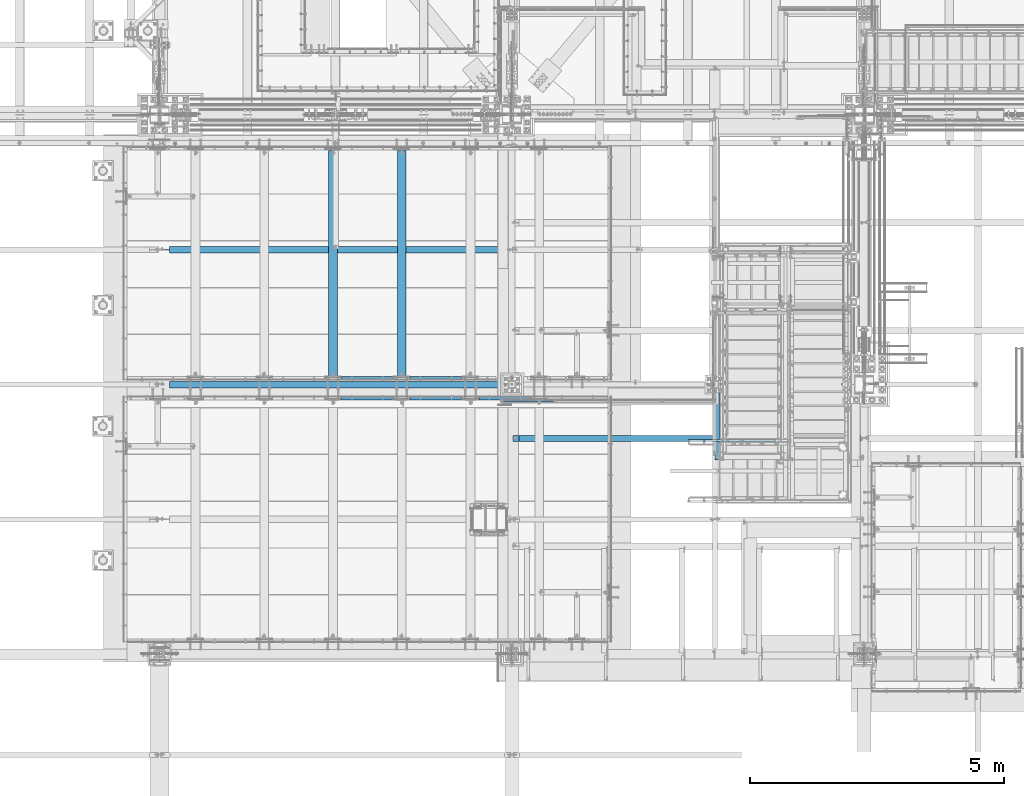
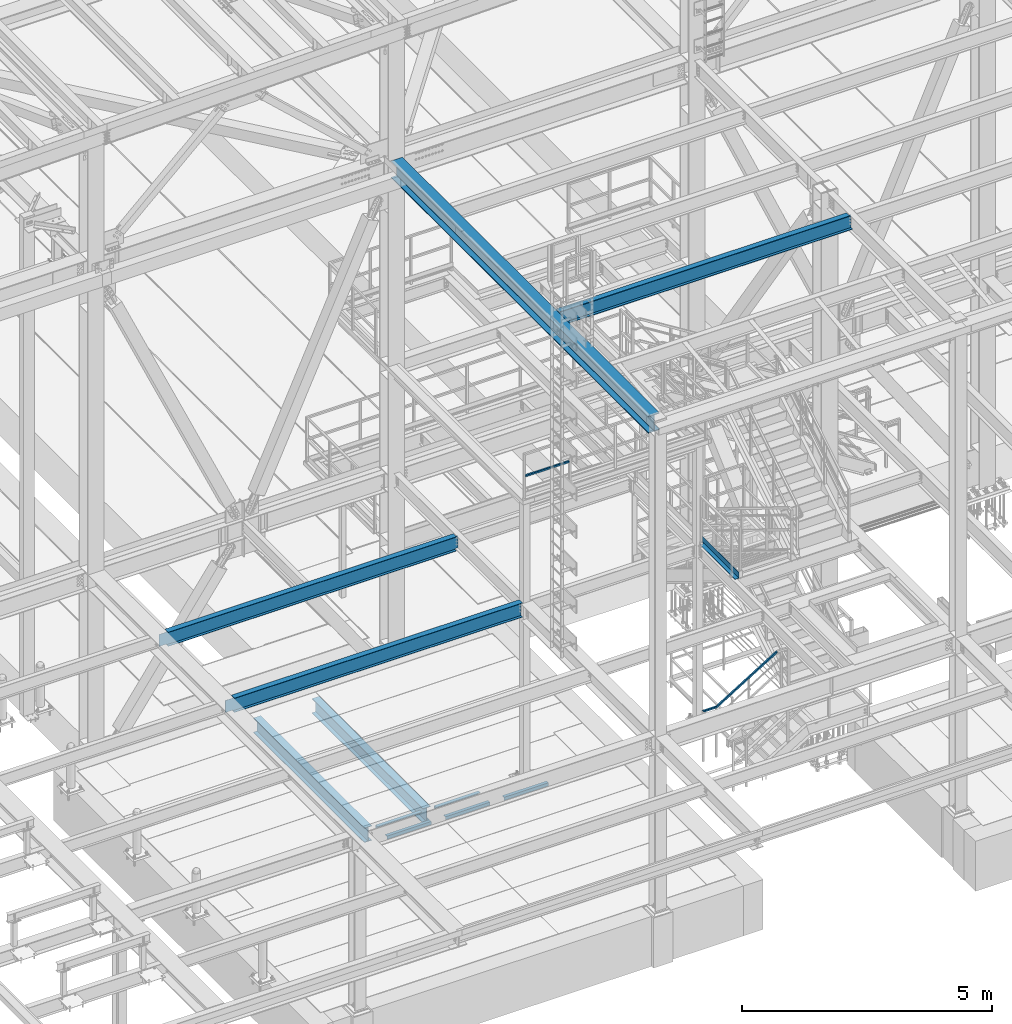
# One storey, part 1756 of 3843: 14 beams, 14 elements without a shape of their own.
"""IFC2X3 building model written with IfcOpenShell, lengths in millimetres."""

from ifc_helpers import new_model, si_unit, frame, origin_with_axes, place, context, subcontext, project, spatial, faceted_brep, material, type_object, element, aggregate, save


model = new_model("IFC2X3")

# Units and contexts
model_context = context("Model", 3, precision=1e-05, world=origin_with_axes())
body_context = subcontext(model_context, "Body", "Model", "MODEL_VIEW")
ifc_project = project(units=[si_unit("LENGTHUNIT", "METRE", prefix="MILLI"), si_unit("AREAUNIT", "SQUARE_METRE"), si_unit("VOLUMEUNIT", "CUBIC_METRE"), si_unit("MASSUNIT", "GRAM", prefix="KILO"), si_unit("TIMEUNIT", "SECOND"), si_unit("PLANEANGLEUNIT", "RADIAN"), si_unit("SOLIDANGLEUNIT", "STERADIAN"), si_unit("THERMODYNAMICTEMPERATUREUNIT", "DEGREE_CELSIUS"), si_unit("LUMINOUSINTENSITYUNIT", "LUMEN")], contexts=[model_context])

# Site, building, storey
site_placement = place(None, origin_with_axes())
site = spatial("IfcSite", under=ifc_project, at=site_placement, CompositionType="ELEMENT")
building_placement = place(site_placement, origin_with_axes())
building = spatial("IfcBuilding", under=site, at=building_placement, Name="Undefined", CompositionType="ELEMENT")
storey_placement = place(building_placement, origin_with_axes())
storey = spatial("IfcBuildingStorey", under=building, at=storey_placement, Name="Undefined", CompositionType="ELEMENT", Elevation=0.0)

# Assembly, beam
assembly_1_placement = place(storey_placement, origin_with_axes())
assembly_1 = element("IfcElementAssembly", 1, at=assembly_1_placement, inside=storey, Name="RAIL", AssemblyPlace="NOTDEFINED", PredefinedType="RIGID_FRAME")
ifc_material_1 = material()
beam_type_1 = type_object("IfcBeamType", Name="HSS1-1/2X1-1/2X1/4", PredefinedType="NOTDEFINED")
beam_1_placement = place(assembly_1_placement, frame((48799.7499877927, 19983.4499877934, 38099.9999983615), z_axis=(0.0, 0.0, 1.0), x_axis=(1.0, 0.0, 0.0)))
beam_1 = element("IfcBeam", 2, at=beam_1_placement, type_object=beam_type_1, material=ifc_material_1, Name="RAIL", ObjectType="HSS1-1/2X1-1/2X1/4", context=body_context, shape_type="Brep", body=[
    faceted_brep([(1027.11250303521, -19.0500000007705, 19.0499992350015), (1027.11250303521, -19.0499992350015, -19.0499992350015), (1027.11250303521, 19.0499992350015, -19.0499992350015), (1027.11250303521, 19.0499992350015, 19.0499992350015), (1027.11250303521, -12.6999993300014, 12.6999993299978), (1027.11250303521, 12.6999993300014, 12.6999993299978), (1027.11250303521, 12.6999993300014, -12.6999993299978), (1027.11250303521, -12.6999993300014, -12.6999993299978), (19.0499992350015, 19.0499992350015, -19.0499992350015), (19.0499992350015, 19.0499992350015, 19.0499992350015), (19.0499992350015, -19.0499992350015, 19.0499992350015), (19.0499992350015, -19.0499992350015, -19.0499992350015), (19.0499992350015, 12.6999993299978, 12.6999993299978), (19.0499992350015, -12.6999993299978, 12.6999993299978), (19.0499992350015, -12.6999993299978, -12.6999993299978), (19.0499992350015, 12.6999993299978, -12.6999993299978)], [[[0, 1, 2, 3], [4, 5, 6, 7]], [[8, 9, 3, 2]], [[9, 10, 0, 3]], [[10, 11, 1, 0]], [[11, 8, 2, 1]], [[11, 10, 9, 8], [12, 13, 14, 15]], [[14, 13, 4, 7]], [[15, 14, 7, 6]], [[12, 15, 6, 5]], [[13, 12, 5, 4]]]),
])
aggregate(assembly_1, [beam_1])

assembly_2_placement = place(storey_placement, origin_with_axes())
assembly_2 = element("IfcElementAssembly", 3, at=assembly_2_placement, inside=storey, Name="RAIL", AssemblyPlace="NOTDEFINED", PredefinedType="RIGID_FRAME")
beam_2_placement = place(assembly_2_placement, frame((54271.9209098939, 19202.4000001452, 32464.1667135371), z_axis=(0.524097425775922, 0.0, -0.851658316635875), x_axis=(-0.851658316635875, 0.0, -0.524097425775922)))
beam_2 = element("IfcBeam", 4, at=beam_2_placement, type_object=beam_type_1, material=ifc_material_1, Name="RAIL", ObjectType="HSS1-1/2X1-1/2X1/4", context=body_context, shape_type="Brep", body=[
    faceted_brep([(1755.76634726612, 19.0499992350015, 19.049998791572), (1755.76634726612, -19.0499992350015, 19.049998791572), (2003.71981394624, -19.0499992350015, -133.536749979445), (2003.71981394624, 19.0499992350015, -133.536749979445), (115.437154328312, 19.0499992350015, 19.0499992058286), (115.437154328312, -19.0499992350015, 19.0499992058286), (1744.98244024127, -19.0499992350015, -19.0499996756661), (2016.19988403501, -19.0499992350015, -185.953042059253), (104.65324729737, -19.0499992350015, -19.0499992614094), (1744.98244024127, 19.0499992350015, -19.0499996756661), (104.65324729737, 19.0499992350015, -19.0499992614094), (2016.19988403501, 19.0499992350015, -185.953042059253), (1746.77975812404, 12.6999993300014, -12.6999997711281), (1746.77975812404, -12.6999993300014, -12.6999997711281), (2014.11987176099, -12.6999993300014, -177.216992826765), (2014.11987176099, 12.6999993300014, -177.216992826765), (2005.79982557208, 12.6999993300014, -142.272798813054), (2005.79982557208, -12.6999993300014, -142.272798813054), (1753.96902938335, -12.6999993300014, 12.699998887034), (1753.96902938335, 12.6999993300014, 12.699998887034), (113.639836444549, -12.6999993300014, 12.699999301287), (113.639836444549, 12.6999993300014, 12.699999301287), (106.450565181156, 12.6999993300014, -12.6999993568714), (106.450565181156, -12.6999993300014, -12.6999993568714)], [[[0, 1, 2, 3]], [[1, 0, 4, 5]], [[6, 7, 2, 1, 5, 8]], [[9, 6, 8, 10]], [[0, 3, 11, 9, 10, 4]], [[6, 9, 11, 7]], [[12, 13, 14, 15]], [[3, 2, 7, 11], [16, 15, 14, 17]], [[18, 19, 16, 17]], [[19, 18, 20, 21]], [[12, 15, 16, 19, 21, 22]], [[13, 12, 22, 23]], [[18, 17, 14, 13, 23, 20]], [[10, 8, 5, 4], [22, 21, 20, 23]]]),
])
aggregate(assembly_2, [beam_2])

assembly_3_placement = place(storey_placement, origin_with_axes())
assembly_3 = element("IfcElementAssembly", 5, at=assembly_3_placement, inside=storey, Name="ANGLE", AssemblyPlace="NOTDEFINED", PredefinedType="RIGID_FRAME")
ifc_material_2 = material(Name="STEEL/A36")
beam_type_2 = type_object("IfcBeamType", Name="L3X3X1/4", PredefinedType="NOTDEFINED")
beam_3_placement = place(assembly_3_placement, frame((48015.5432658982, 20424.7750055596, 30365.7000030518), z_axis=(0.0, 0.0, -1.0), x_axis=(-1.0, 0.0, 0.0)))
beam_3 = element("IfcBeam", 6, at=beam_3_placement, type_object=beam_type_2, material=ifc_material_2, Name="ANGLE", ObjectType="L3X3X1/4", context=body_context, shape_type="Brep", body=[
    faceted_brep([(0.0, 38.0999999999985, -38.0999999999985), (0.0, 38.0999999999985, 38.0999999999985), (1022.33317453146, 38.1000000000004, 38.0999999999985), (1022.33317453146, 38.1000000000004, -38.0999999999985), (0.0, 31.75, 38.0999999999985), (1022.33317453146, 31.75, 38.0999999999985), (0.0, 31.75, -31.75), (1022.33317453146, 31.75, -31.75), (0.0, -38.0999999999985, -31.75), (1022.33317453146, -38.1000000000004, -31.75), (0.0, -38.0999999999985, -38.0999999999985), (1022.33317453146, -38.1000000000004, -38.0999999999985)], [[[0, 1, 2, 3]], [[1, 4, 5, 2]], [[4, 6, 7, 5]], [[6, 8, 9, 7]], [[8, 10, 11, 9]], [[10, 0, 3, 11]], [[5, 7, 9, 11, 3, 2]], [[10, 8, 6, 4, 1, 0]]]),
])
aggregate(assembly_3, [beam_3])

assembly_4_placement = place(storey_placement, origin_with_axes())
assembly_4 = element("IfcElementAssembly", 7, at=assembly_4_placement, inside=storey, Name="ANGLE", AssemblyPlace="NOTDEFINED", PredefinedType="RIGID_FRAME")
beam_4_placement = place(assembly_4_placement, frame((46662.9932658982, 20424.7750055596, 30365.7000030518), z_axis=(0.0, 0.0, -1.0), x_axis=(-1.0, 0.0, 0.0)))
beam_4 = element("IfcBeam", 8, at=beam_4_placement, type_object=beam_type_2, material=ifc_material_2, Name="ANGLE", ObjectType="L3X3X1/4", context=body_context, shape_type="Brep", body=[
    faceted_brep([(0.0, 38.0999999999985, -38.0999999999985), (0.0, 38.0999999999985, 38.0999999999985), (1022.33317453146, 38.1000000000004, 38.0999999999985), (1022.33317453146, 38.1000000000004, -38.0999999999985), (0.0, 31.75, 38.0999999999985), (1022.33317453146, 31.75, 38.0999999999985), (0.0, 31.75, -31.75), (1022.33317453146, 31.75, -31.75), (0.0, -38.0999999999985, -31.75), (1022.33317453146, -38.1000000000004, -31.75), (0.0, -38.0999999999985, -38.0999999999985), (1022.33317453146, -38.1000000000004, -38.0999999999985)], [[[0, 1, 2, 3]], [[1, 4, 5, 2]], [[4, 6, 7, 5]], [[6, 8, 9, 7]], [[8, 10, 11, 9]], [[10, 0, 3, 11]], [[5, 7, 9, 11, 3, 2]], [[10, 8, 6, 4, 1, 0]]]),
])
aggregate(assembly_4, [beam_4])

assembly_5_placement = place(storey_placement, origin_with_axes())
assembly_5 = element("IfcElementAssembly", 9, at=assembly_5_placement, inside=storey, Name="ANGLE", AssemblyPlace="NOTDEFINED", PredefinedType="RIGID_FRAME")
beam_5_placement = place(assembly_5_placement, frame((48345.7242797851, 20043.7749980702, 30365.7000030518), z_axis=(0.0, 0.0, -1.0), x_axis=(1.0, 0.0, 0.0)))
beam_5 = element("IfcBeam", 10, at=beam_5_placement, type_object=beam_type_2, material=ifc_material_2, Name="ANGLE", ObjectType="L3X3X1/4", context=body_context, shape_type="Brep", body=[
    faceted_brep([(0.0, 38.0999999999985, -38.0999999999985), (0.0, 38.0999999999985, 38.0999999999985), (1022.33317453146, 38.1000000000004, 38.0999999999985), (1022.33317453146, 38.1000000000004, -38.0999999999985), (0.0, 31.75, 38.0999999999985), (1022.33317453146, 31.75, 38.0999999999985), (0.0, 31.75, -31.75), (1022.33317453146, 31.75, -31.75), (0.0, -38.0999999999985, -31.75), (1022.33317453146, -38.1000000000004, -31.75), (0.0, -38.0999999999985, -38.0999999999985), (1022.33317453146, -38.1000000000004, -38.0999999999985)], [[[0, 1, 2, 3]], [[1, 4, 5, 2]], [[4, 6, 7, 5]], [[6, 8, 9, 7]], [[8, 10, 11, 9]], [[10, 0, 3, 11]], [[5, 7, 9, 11, 3, 2]], [[10, 8, 6, 4, 1, 0]]]),
])
aggregate(assembly_5, [beam_5])

assembly_6_placement = place(storey_placement, origin_with_axes())
assembly_6 = element("IfcElementAssembly", 11, at=assembly_6_placement, inside=storey, Name="ANGLE", AssemblyPlace="NOTDEFINED", PredefinedType="RIGID_FRAME")
beam_6_placement = place(assembly_6_placement, frame((46993.1742797851, 20043.7749972574, 30365.7000030518), z_axis=(0.0, 0.0, -1.0), x_axis=(1.0, 0.0, 0.0)))
beam_6 = element("IfcBeam", 12, at=beam_6_placement, type_object=beam_type_2, material=ifc_material_2, Name="ANGLE", ObjectType="L3X3X1/4", context=body_context, shape_type="Brep", body=[
    faceted_brep([(0.0, 38.0999999999985, -38.0999999999985), (0.0, 38.0999999999985, 38.0999999999985), (1022.33317453146, 38.1000000000004, 38.0999999999985), (1022.33317453146, 38.1000000000004, -38.0999999999985), (0.0, 31.75, 38.0999999999985), (1022.33317453146, 31.75, 38.0999999999985), (0.0, 31.75, -31.75), (1022.33317453146, 31.75, -31.75), (0.0, -38.0999999999985, -31.75), (1022.33317453146, -38.1000000000004, -31.75), (0.0, -38.0999999999985, -38.0999999999985), (1022.33317453146, -38.1000000000004, -38.0999999999985)], [[[0, 1, 2, 3]], [[1, 4, 5, 2]], [[4, 6, 7, 5]], [[6, 8, 9, 7]], [[8, 10, 11, 9]], [[10, 0, 3, 11]], [[5, 7, 9, 11, 3, 2]], [[10, 8, 6, 4, 1, 0]]]),
])
aggregate(assembly_6, [beam_6])

assembly_7_placement = place(storey_placement, origin_with_axes())
assembly_7 = element("IfcElementAssembly", 13, at=assembly_7_placement, inside=storey, Name="ANGLE", AssemblyPlace="NOTDEFINED", PredefinedType="RIGID_FRAME")
beam_7_placement = place(assembly_7_placement, frame((45640.6242797851, 20043.7749970828, 30365.7000030518), z_axis=(0.0, 0.0, -1.0), x_axis=(1.0, 0.0, 0.0)))
beam_7 = element("IfcBeam", 14, at=beam_7_placement, type_object=beam_type_2, material=ifc_material_2, Name="ANGLE", ObjectType="L3X3X1/4", context=body_context, shape_type="Brep", body=[
    faceted_brep([(0.0, 38.0999999999985, -38.0999999999985), (0.0, 38.0999999999985, 38.0999999999985), (1022.33317453146, 38.1000000000004, 38.0999999999985), (1022.33317453146, 38.1000000000004, -38.0999999999985), (0.0, 31.75, 38.0999999999985), (1022.33317453146, 31.75, 38.0999999999985), (0.0, 31.75, -31.75), (1022.33317453146, 31.75, -31.75), (0.0, -38.0999999999985, -31.75), (1022.33317453146, -38.1000000000004, -31.75), (0.0, -38.0999999999985, -38.0999999999985), (1022.33317453146, -38.1000000000004, -38.0999999999985)], [[[0, 1, 2, 3]], [[1, 4, 5, 2]], [[4, 6, 7, 5]], [[6, 8, 9, 7]], [[8, 10, 11, 9]], [[10, 0, 3, 11]], [[5, 7, 9, 11, 3, 2]], [[10, 8, 6, 4, 1, 0]]]),
])
aggregate(assembly_7, [beam_7])

assembly_8_placement = place(storey_placement, origin_with_axes())
assembly_8 = element("IfcElementAssembly", 15, at=assembly_8_placement, inside=storey, Name="BEAM", AssemblyPlace="NOTDEFINED", PredefinedType="RIGID_FRAME")
beam_type_3 = type_object("IfcBeamType", PredefinedType="NOTDEFINED")
beam_8_placement = place(assembly_8_placement, frame((52990.75, 19562.7625, 34813.875), z_axis=(0.0, -1.0, 0.0), x_axis=(1.0, 0.0, 0.0)))
beam_8 = element("IfcBeam", 16, at=beam_8_placement, type_object=beam_type_3, material=ifc_material_2, Name="BENT_PLATE", context=body_context, shape_type="Brep", body=[
    faceted_brep([(82.5500030517578, -3.17500000000291, -655.637500000001), (82.5500030517578, 3.17500000000291, -655.637500000001), (82.5500030517578, 3.17500000000291, -741.362499999999), (82.5500030517578, -3.17500000000291, -741.362499999999), (0.0, -3.17500000000291, -655.637500000001), (0.0, 3.17500000000291, -655.637500000001), (88.8999984741167, 3.17500000000291, 741.362499999999), (0.0, 3.17500000000291, 741.362499999999), (0.0, -3.17500000000291, 741.362499999999), (95.2499984741225, -3.17500000000291, 741.362499999999), (95.2499984741225, 136.524996948239, 741.362499999999), (88.8999984741167, 136.524996948239, 741.362499999999), (88.8999984741167, 3.17500000000291, -741.362499999999), (88.8999984741167, 136.524996948239, -741.362499999999), (95.2499984741225, 136.524996948239, -741.362499999999), (95.2499984741225, -3.17500000000291, -741.362499999999)], [[[0, 1, 2, 3]], [[4, 5, 1, 0]], [[6, 7, 8, 9, 10, 11]], [[12, 6, 11, 13]], [[10, 14, 13, 11]], [[9, 15, 14, 10]], [[12, 13, 14, 15, 3, 2]], [[7, 6, 12, 2, 1, 5]], [[8, 7, 5, 4]], [[15, 9, 8, 4, 0, 3]]]),
])
aggregate(assembly_8, [beam_8])

assembly_9_placement = place(storey_placement, origin_with_axes())
assembly_9 = element("IfcElementAssembly", 17, at=assembly_9_placement, inside=storey, Name="BEAM", AssemblyPlace="NOTDEFINED", PredefinedType="RIGID_FRAME")
ifc_material_3 = material(Name="STEEL/A992")
beam_type_4 = type_object("IfcBeamType", Name="W16X67", PredefinedType="NOTDEFINED")
beam_9_placement = place(assembly_9_placement, frame((48996.6, 14998.7, 42260.8375), z_axis=(0.0, 0.0, 1.0), x_axis=(0.0, 1.0, 0.0)))
beam_9 = element("IfcBeam", 18, at=beam_9_placement, type_object=beam_type_4, material=ifc_material_3, Name="BEAM", ObjectType="W16X67", context=body_context, shape_type="Brep", body=[
    faceted_brep([(142.874999999998, -130.175000000003, -207.962500000001), (142.874999999998, 130.175000000003, -207.962500000001), (10426.7, 130.175000000003, -207.962500000001), (10426.7, -130.175000000003, -207.962500000001), (142.874999999998, -130.175000000003, -190.5), (142.874999999998, -4.76249999999709, -190.5), (142.874999999998, -4.76249999999709, 190.5), (142.874999999998, -130.175000000003, 190.5), (142.874999999998, -130.175000000003, 207.962500000001), (142.874999999998, 130.175000000003, 207.962500000001), (142.874999999998, 130.175000000003, 190.5), (142.874999999998, 4.76249999999709, 190.5), (142.874999999998, 4.76249999999709, -190.5), (142.874999999998, 130.175000000003, -190.5), (10426.7, -130.175000000003, -190.5), (10426.7, -4.76249999999709, -190.5), (10426.7, -4.76249999999709, 190.5), (10426.7, -130.175000000003, 190.5), (10426.7, -130.175000000003, 207.962500000001), (10426.7, 130.175000000003, 207.962500000001), (10426.7, 130.175000000003, 190.5), (10426.7, 4.76249999999709, 190.5), (10426.7, 4.76249999999709, -190.5), (10426.7, 130.175000000003, -190.5)], [[[0, 1, 2, 3]], [[0, 4, 5, 6, 7, 8, 9, 10, 11, 12, 13, 1]], [[5, 4, 14, 15]], [[6, 5, 15, 16]], [[7, 6, 16, 17]], [[8, 7, 17, 18]], [[9, 8, 18, 19]], [[10, 9, 19, 20]], [[11, 10, 20, 21]], [[12, 11, 21, 22]], [[13, 12, 22, 23]], [[1, 13, 23, 2]], [[22, 21, 20, 19, 18, 17, 16, 15, 14, 3, 2, 23]], [[4, 0, 3, 14]]]),
])
aggregate(assembly_9, [beam_9])

assembly_10_placement = place(storey_placement, origin_with_axes())
assembly_10 = element("IfcElementAssembly", 19, at=assembly_10_placement, inside=storey, Name="BEAM", AssemblyPlace="NOTDEFINED", PredefinedType="RIGID_FRAME")
beam_type_5 = type_object("IfcBeamType", Name="W14X26", PredefinedType="NOTDEFINED")
beam_10_placement = place(assembly_10_placement, frame((48996.6, 19245.58, 42292.5875), z_axis=(0.0, 0.0, 1.0), x_axis=(1.0, 0.0, 0.0)))
beam_10 = element("IfcBeam", 20, at=beam_10_placement, type_object=beam_type_5, material=ifc_material_3, Name="BEAM", ObjectType="W14X26", context=body_context, shape_type="Brep", body=[
    faceted_brep([(6851.64999694825, -63.5, 176.212500000001), (6851.64999694825, -63.5, 165.099999999999), (6851.64999694825, -3.17499999999927, 165.099999999999), (6851.64999694825, -3.17499999999927, 160.33749980927), (6851.64999694825, 3.17499999999927, 160.33749980927), (6851.64999694825, 3.17499999999927, 165.099999999999), (6851.64999694825, 63.5, 165.099999999999), (6851.64999694825, 63.5, 176.212500000001), (6852.61672687083, -3.17499999999927, 155.477420291223), (6852.61672687083, 3.17499999999927, 155.477420291223), (6855.36974077131, -3.17499999999927, 151.357243823069), (6855.36974077131, 3.17499999999927, 151.357243823069), (6859.48991723947, -3.17499999999927, 148.604229922596), (6859.48991723947, 3.17499999999927, 148.604229922596), (6864.34999675751, -3.17499999999927, 147.637500000004), (6864.34999675751, 3.17499999999927, 147.637500000004), (6918.325, -3.17499999999927, 147.637500000004), (6918.325, 3.17499999999927, 147.637500000004), (142.87500610351, -63.5, 176.212500000001), (142.87500610351, 63.5, 176.212500000001), (142.87500610351, 63.5, 165.099999999999), (142.87500610351, 3.17499999999927, 165.099999999999), (142.87500610351, 3.17499999999927, 149.224999809267), (142.87500610351, -3.17499999999927, 149.224999809267), (142.87500610351, -3.17499999999927, 165.099999999999), (142.87500610351, -63.5, 165.099999999999), (141.908276180919, 3.17499999999927, 144.36492029122), (141.908276180919, -3.17499999999927, 144.36492029122), (139.155262280445, 3.17499999999927, 140.244743823067), (139.155262280445, -3.17499999999927, 140.244743823067), (135.035085812291, 3.17499999999927, 137.491729922593), (135.035085812291, -3.17499999999927, 137.491729922593), (130.175006294245, 3.17499999999927, 136.525000000001), (130.175006294245, -3.17499999999927, 136.525000000001), (17.4624999999942, 3.17499999999927, 136.525000000001), (17.4624999999942, -3.17499999999927, 136.525000000001), (17.4624999999942, 3.17499999999927, 125.412499999999), (17.4624999999942, 3.17499999999927, -105.1875), (17.4624999999942, 3.17499999999927, -165.099999999999), (17.4624999999942, 63.5, -165.099999999999), (17.4624999999942, 63.5, -176.212500000001), (17.4624999999942, -63.5, -176.212500000001), (17.4624999999942, -63.5, -165.099999999999), (17.4624999999942, -3.17499999999927, -165.099999999999), (6918.325, 3.17499999999927, -165.099999999999), (6918.325, 63.5, -165.099999999999), (6918.325, 63.5, -176.212500000001), (6918.325, -63.5, -176.212500000001), (6918.325, -63.5, -165.099999999999), (6918.325, -3.17499999999927, -165.099999999999), (6918.325, 3.17499999999927, 125.412499999999), (6918.325, 3.17499999999927, -105.1875)], [[[0, 1, 2, 3, 4, 5, 6, 7]], [[8, 9, 4, 3]], [[10, 11, 9, 8]], [[12, 13, 11, 10]], [[14, 15, 13, 12]], [[16, 17, 15, 14]], [[18, 19, 20, 21, 22, 23, 24, 25]], [[23, 22, 26, 27]], [[27, 26, 28, 29]], [[29, 28, 30, 31]], [[31, 30, 32, 33]], [[33, 32, 34, 35]], [[36, 37, 38, 39, 40, 41, 42, 43, 35, 34]], [[39, 38, 44, 45]], [[40, 39, 45, 46]], [[41, 40, 46, 47]], [[42, 41, 47, 48]], [[43, 42, 48, 49]], [[12, 10, 8, 3, 2, 24, 23, 27, 29, 31, 33, 35, 43, 49, 16, 14]], [[25, 24, 2, 1]], [[18, 25, 1, 0]], [[19, 18, 0, 7]], [[20, 19, 7, 6]], [[21, 20, 6, 5]], [[50, 51, 44, 38, 37, 36, 34, 32, 30, 28, 26, 22, 21, 5, 4, 9, 11, 13, 15, 17]], [[49, 48, 47, 46, 45, 44, 51, 50, 17, 16]]]),
])
aggregate(assembly_10, [beam_10])

assembly_11_placement = place(storey_placement, origin_with_axes())
assembly_11 = element("IfcElementAssembly", 21, at=assembly_11_placement, inside=storey, Name="BEAM", AssemblyPlace="NOTDEFINED", PredefinedType="RIGID_FRAME")
beam_type_6 = type_object("IfcBeamType", Name="W14X22", PredefinedType="NOTDEFINED")
beam_11_placement = place(assembly_11_placement, frame((42062.4, 20307.3, 34636.075), z_axis=(0.0, 0.0, 1.0), x_axis=(1.0, 0.0, 0.0)))
beam_11 = element("IfcBeam", 22, at=beam_11_placement, type_object=beam_type_6, material=ifc_material_3, Name="BEAM", ObjectType="W14X22", context=body_context, shape_type="Brep", body=[
    faceted_brep([(6845.3, -63.5, 166.6875), (6845.3, -63.5, 174.625), (196.849999999999, -63.5, 174.625), (196.849999999999, -63.5, 166.6875), (6845.3, 63.5, 174.625), (196.849999999999, 63.5, 174.625), (6845.3, 63.5, 166.6875), (196.849999999999, 63.5, 166.6875), (6845.3, 3.17499999999927, 166.6875), (196.849999999999, 3.17499999999927, 166.6875), (184.150000190733, -3.17499999999927, 142.874999999985), (184.150000190733, 3.17499999999927, 142.874999999985), (19.0499999999956, 3.17499999999927, 142.874999999985), (19.0499999999956, -3.17499999999927, 142.874999999985), (189.01007970878, -3.17499999999927, 143.841729922577), (189.01007970878, 3.17499999999927, 143.841729922577), (193.130256176933, -3.17499999999927, 146.594743823051), (193.130256176933, 3.17499999999927, 146.594743823051), (195.883270077407, -3.17499999999927, 150.714920291204), (195.883270077407, 3.17499999999927, 150.714920291204), (196.849999999999, -3.17499999999927, 155.574999809251), (196.849999999999, 3.17499999999927, 155.574999809251), (196.849999999999, -3.17499999999927, 166.6875), (6845.3, -3.17499999999927, 166.6875), (6845.3, 3.17499999999927, -166.6875), (6845.3, -3.17499999999927, -166.6875), (6845.3, -63.5, -166.6875), (6845.3, -63.5, -174.625), (6845.3, 63.5, -174.625), (6845.3, 63.5, -166.6875), (196.850000000006, -63.5, -166.6875), (196.850000000006, -63.5, -174.625), (196.850000000006, 63.5, -174.625), (196.850000000006, 63.5, -166.6875), (196.850000000006, 3.17499999999927, -166.6875), (193.130256176941, 3.17499999999927, -152.944743823078), (189.010079708787, 3.17499999999927, -150.191729922604), (184.150000190741, 3.17499999999927, -149.225000000013), (19.0499999999956, 3.17499999999927, -149.225000000013), (19.0499999999956, 3.17499999999927, -106.775000000001), (19.0499999999956, 3.17499999999927, 123.824999999997), (196.850000000006, 3.17499999999927, -161.924999809278), (195.883270077415, 3.17499999999927, -157.064920291232), (19.0499999999956, -3.17499999999927, -149.225000000013), (184.150000190741, -3.17499999999927, -149.225000000013), (189.010079708787, -3.17499999999927, -150.191729922604), (193.130256176941, -3.17499999999927, -152.944743823078), (195.883270077415, -3.17499999999927, -157.064920291232), (196.850000000006, -3.17499999999927, -161.924999809278), (196.850000000006, -3.17499999999927, -166.6875)], [[[0, 1, 2, 3]], [[1, 4, 5, 2]], [[4, 6, 7, 5]], [[6, 8, 9, 7]], [[10, 11, 12, 13]], [[14, 15, 11, 10]], [[16, 17, 15, 14]], [[18, 19, 17, 16]], [[20, 21, 19, 18]], [[2, 5, 7, 9, 21, 20, 22, 3]], [[23, 0, 3, 22]], [[24, 8, 6, 4, 1, 0, 23, 25, 26, 27, 28, 29]], [[27, 26, 30, 31]], [[28, 27, 31, 32]], [[29, 28, 32, 33]], [[24, 29, 33, 34]], [[35, 36, 37, 38, 39, 40, 12, 11, 15, 17, 19, 21, 9, 8, 24, 34, 41, 42]], [[13, 12, 40, 39, 38, 43]], [[25, 23, 22, 20, 18, 16, 14, 10, 13, 43, 44, 45, 46, 47, 48, 49]], [[26, 25, 49, 30]], [[48, 41, 34, 33, 32, 31, 30, 49]], [[47, 42, 41, 48]], [[46, 35, 42, 47]], [[45, 36, 35, 46]], [[44, 37, 36, 45]], [[43, 38, 37, 44]]]),
])
aggregate(assembly_11, [beam_11])

assembly_12_placement = place(storey_placement, origin_with_axes())
assembly_12 = element("IfcElementAssembly", 23, at=assembly_12_placement, inside=storey, Name="BEAM", AssemblyPlace="NOTDEFINED", PredefinedType="RIGID_FRAME")
beam_12_placement = place(assembly_12_placement, frame((42062.4, 22961.6, 34636.075), z_axis=(0.0, 0.0, 1.0), x_axis=(1.0, 0.0, 0.0)))
beam_12 = element("IfcBeam", 24, at=beam_12_placement, type_object=beam_type_6, material=ifc_material_3, Name="BEAM", ObjectType="W14X22", context=body_context, shape_type="Brep", body=[
    faceted_brep([(6854.825, -3.17499999999927, -166.6875), (6854.825, -63.5, -166.6875), (6854.825, -63.5, -174.625), (6854.825, 63.5, -174.625), (6854.825, 63.5, -166.6875), (6854.825, 3.17499999999927, -166.6875), (6854.825, 3.17499999999927, -161.924999809264), (6854.825, -3.17499999999927, -161.924999809264), (6855.79172992259, 3.17499999999927, -157.064920291217), (6855.79172992259, -3.17499999999927, -157.064920291217), (6858.54474382306, 3.17499999999927, -152.944743823064), (6858.54474382306, -3.17499999999927, -152.944743823064), (6862.66492029122, 3.17499999999927, -150.19172992259), (6862.66492029122, -3.17499999999927, -150.19172992259), (6867.52499980926, 3.17499999999927, -149.224999999999), (6867.52499980926, -3.17499999999927, -149.224999999999), (6918.325, -3.17499999999927, -149.224999999999), (6918.325, 3.17499999999927, -149.224999999999), (196.849999999999, 3.17499999999927, 166.6875), (196.849999999999, 63.5, 166.6875), (6854.825, 63.5, 166.6875), (6854.825, 3.17499999999927, 166.6875), (196.850000000006, -3.17499999999927, -161.924999809278), (196.850000000006, 3.17499999999927, -161.924999809278), (196.850000000006, 3.17499999999927, -166.6875), (196.850000000006, 63.5, -166.6875), (196.850000000006, 63.5, -174.625), (196.850000000006, -63.5, -174.625), (196.850000000006, -63.5, -166.6875), (196.850000000006, -3.17499999999927, -166.6875), (195.883270077415, -3.17499999999927, -157.064920291232), (195.883270077415, 3.17499999999927, -157.064920291232), (193.130256176941, -3.17499999999927, -152.944743823078), (193.130256176941, 3.17499999999927, -152.944743823078), (189.010079708787, -3.17499999999927, -150.191729922604), (189.010079708787, 3.17499999999927, -150.191729922604), (184.150000190741, -3.17499999999927, -149.225000000013), (184.150000190741, 3.17499999999927, -149.225000000013), (19.0499999999956, -3.17499999999927, -149.225000000013), (19.0499999999956, 3.17499999999927, -149.225000000013), (19.0499999999956, -3.17499999999927, 142.874999999985), (19.0499999999956, 3.17499999999927, 142.874999999985), (19.0499999999956, 3.17499999999927, 123.824999999997), (19.0499999999956, 3.17499999999927, -106.775000000001), (184.150000190733, -3.17499999999927, 142.874999999985), (184.150000190733, 3.17499999999927, 142.874999999985), (189.01007970878, -3.17499999999927, 143.841729922577), (189.01007970878, 3.17499999999927, 143.841729922577), (193.130256176933, -3.17499999999927, 146.594743823051), (193.130256176933, 3.17499999999927, 146.594743823051), (195.883270077407, -3.17499999999927, 150.714920291204), (195.883270077407, 3.17499999999927, 150.714920291204), (196.849999999999, -3.17499999999927, 155.574999809251), (196.849999999999, 3.17499999999927, 155.574999809251), (196.849999999999, -63.5, 174.625), (196.849999999999, 63.5, 174.625), (196.849999999999, -3.17499999999927, 166.6875), (196.849999999999, -63.5, 166.6875), (6854.825, -3.17499999999927, 166.6875), (6854.825, -63.5, 166.6875), (6854.825, -63.5, 174.625), (6854.825, 63.5, 174.625), (6854.825, -3.17499999999927, 161.924999809264), (6854.825, 3.17499999999927, 161.924999809264), (6855.79172992259, -3.17499999999927, 157.064920291217), (6855.79172992259, 3.17499999999927, 157.064920291217), (6858.54474382306, -3.17499999999927, 152.944743823064), (6858.54474382306, 3.17499999999927, 152.944743823064), (6862.66492029122, -3.17499999999927, 150.19172992259), (6862.66492029122, 3.17499999999927, 150.19172992259), (6867.52499980926, -3.17499999999927, 149.224999999999), (6867.52499980926, 3.17499999999927, 149.224999999999), (6918.325, -3.17499999999927, 149.224999999999), (6918.325, 3.17499999999927, 149.224999999999), (6918.325, 3.17499999999927, -94.0749999999971), (6918.325, 3.17499999999927, 136.525000000001)], [[[0, 1, 2, 3, 4, 5, 6, 7]], [[7, 6, 8, 9]], [[9, 8, 10, 11]], [[11, 10, 12, 13]], [[13, 12, 14, 15]], [[16, 15, 14, 17]], [[18, 19, 20, 21]], [[22, 23, 24, 25, 26, 27, 28, 29]], [[30, 31, 23, 22]], [[32, 33, 31, 30]], [[34, 35, 33, 32]], [[36, 37, 35, 34]], [[38, 39, 37, 36]], [[40, 41, 42, 43, 39, 38]], [[44, 45, 41, 40]], [[46, 47, 45, 44]], [[48, 49, 47, 46]], [[50, 51, 49, 48]], [[52, 53, 51, 50]], [[54, 55, 19, 18, 53, 52, 56, 57]], [[57, 56, 58, 59]], [[54, 57, 59, 60]], [[55, 54, 60, 61]], [[19, 55, 61, 20]], [[60, 59, 58, 62, 63, 21, 20, 61]], [[64, 65, 63, 62]], [[66, 67, 65, 64]], [[68, 69, 67, 66]], [[70, 71, 69, 68]], [[72, 73, 71, 70]], [[74, 75, 73, 72, 16, 17]], [[12, 10, 8, 6, 5, 24, 23, 31, 33, 35, 37, 39, 43, 42, 41, 45, 47, 49, 51, 53, 18, 21, 63, 65, 67, 69, 71, 73, 75, 74, 17, 14]], [[25, 24, 5, 4]], [[26, 25, 4, 3]], [[27, 26, 3, 2]], [[28, 27, 2, 1]], [[29, 28, 1, 0]], [[72, 70, 68, 66, 64, 62, 58, 56, 52, 50, 48, 46, 44, 40, 38, 36, 34, 32, 30, 22, 29, 0, 7, 9, 11, 13, 15, 16]]]),
])
aggregate(assembly_12, [beam_12])

assembly_13_placement = place(storey_placement, origin_with_axes())
assembly_13 = element("IfcElementAssembly", 25, at=assembly_13_placement, inside=storey, Name="BEAM", AssemblyPlace="NOTDEFINED", PredefinedType="RIGID_FRAME")
beam_type_7 = type_object("IfcBeamType", Name="W14X38", PredefinedType="NOTDEFINED")
beam_13_placement = place(assembly_13_placement, frame((46828.075, 20462.875, 30224.4125), z_axis=(0.0, 0.0, 1.0), x_axis=(0.0, 1.0, 0.0)))
beam_13 = element("IfcBeam", 26, at=beam_13_placement, type_object=beam_type_7, material=ifc_material_3, Name="BEAM", ObjectType="W14X38", context=body_context, shape_type="Brep", body=[
    faceted_brep([(12.7000030517447, 85.7249999999985, -179.387500000001), (12.7000030517447, 85.7249999999985, -166.6875), (4448.17499694826, 85.7249999999985, -166.6875), (4448.17499694826, 85.7249999999985, -179.387500000001), (12.7000030517447, 3.96875, -166.6875), (4448.17499694826, 3.96875, -166.6875), (12.7000030517447, 3.96875, 166.6875), (4448.17499694826, 3.96875, 166.6875), (12.7000030517447, 85.7249999999985, 166.6875), (4448.17499694826, 85.7249999999985, 166.6875), (12.7000030517447, 85.7249999999985, 179.387500000001), (4448.17499694826, 85.7249999999985, 179.387500000001), (12.7000030517447, -85.7249999999985, 179.387500000001), (4448.17499694826, -85.7249999999985, 179.387500000001), (12.7000030517447, -85.7249999999985, 166.6875), (4448.17499694826, -85.7249999999985, 166.6875), (12.7000030517447, -3.96875, 166.6875), (4448.17499694826, -3.96875, 166.6875), (12.7000030517447, -3.96875, -166.6875), (4448.17499694826, -3.96875, -166.6875), (12.7000030517447, -85.7249999999985, -166.6875), (4448.17499694826, -85.7249999999985, -166.6875), (12.7000030517447, -85.7249999999985, -179.387500000001), (4448.17499694826, -85.7249999999985, -179.387500000001)], [[[0, 1, 2, 3]], [[1, 4, 5, 2]], [[4, 6, 7, 5]], [[6, 8, 9, 7]], [[8, 10, 11, 9]], [[10, 12, 13, 11]], [[12, 14, 15, 13]], [[14, 16, 17, 15]], [[16, 18, 19, 17]], [[18, 20, 21, 19]], [[20, 22, 23, 21]], [[22, 0, 3, 23]], [[5, 7, 9, 11, 13, 15, 17, 19, 21, 23, 3, 2]], [[22, 20, 18, 16, 14, 12, 10, 8, 6, 4, 1, 0]]]),
])
aggregate(assembly_13, [beam_13])

assembly_14_placement = place(storey_placement, origin_with_axes())
assembly_14 = element("IfcElementAssembly", 27, at=assembly_14_placement, inside=storey, Name="BEAM", AssemblyPlace="NOTDEFINED", PredefinedType="RIGID_FRAME")
beam_14_placement = place(assembly_14_placement, frame((45475.525, 20462.875, 30224.4125), z_axis=(0.0, 0.0, 1.0), x_axis=(0.0, 1.0, 0.0)))
beam_14 = element("IfcBeam", 28, at=beam_14_placement, type_object=beam_type_7, material=ifc_material_3, Name="BEAM", ObjectType="W14X38", context=body_context, shape_type="Brep", body=[
    faceted_brep([(12.7000030517447, 85.7249999999985, -179.387500000001), (12.7000030517447, 85.7249999999985, -166.6875), (4448.17499694826, 85.7249999999985, -166.6875), (4448.17499694826, 85.7249999999985, -179.387500000001), (12.7000030517447, 3.96875, -166.6875), (4448.17499694826, 3.96875, -166.6875), (12.7000030517447, 3.96875, 166.6875), (4448.17499694826, 3.96875, 166.6875), (12.7000030517447, 85.7249999999985, 166.6875), (4448.17499694826, 85.7249999999985, 166.6875), (12.7000030517447, 85.7249999999985, 179.387500000001), (4448.17499694826, 85.7249999999985, 179.387500000001), (12.7000030517447, -85.7249999999985, 179.387500000001), (4448.17499694826, -85.7249999999985, 179.387500000001), (12.7000030517447, -85.7249999999985, 166.6875), (4448.17499694826, -85.7249999999985, 166.6875), (12.7000030517447, -3.96875, 166.6875), (4448.17499694826, -3.96875, 166.6875), (12.7000030517447, -3.96875, -166.6875), (4448.17499694826, -3.96875, -166.6875), (12.7000030517447, -85.7249999999985, -166.6875), (4448.17499694826, -85.7249999999985, -166.6875), (12.7000030517447, -85.7249999999985, -179.387500000001), (4448.17499694826, -85.7249999999985, -179.387500000001)], [[[0, 1, 2, 3]], [[1, 4, 5, 2]], [[4, 6, 7, 5]], [[6, 8, 9, 7]], [[8, 10, 11, 9]], [[10, 12, 13, 11]], [[12, 14, 15, 13]], [[14, 16, 17, 15]], [[16, 18, 19, 17]], [[18, 20, 21, 19]], [[20, 22, 23, 21]], [[22, 0, 3, 23]], [[5, 7, 9, 11, 13, 15, 17, 19, 21, 23, 3, 2]], [[22, 20, 18, 16, 14, 12, 10, 8, 6, 4, 1, 0]]]),
])
aggregate(assembly_14, [beam_14])

save(model, "model.ifc")
